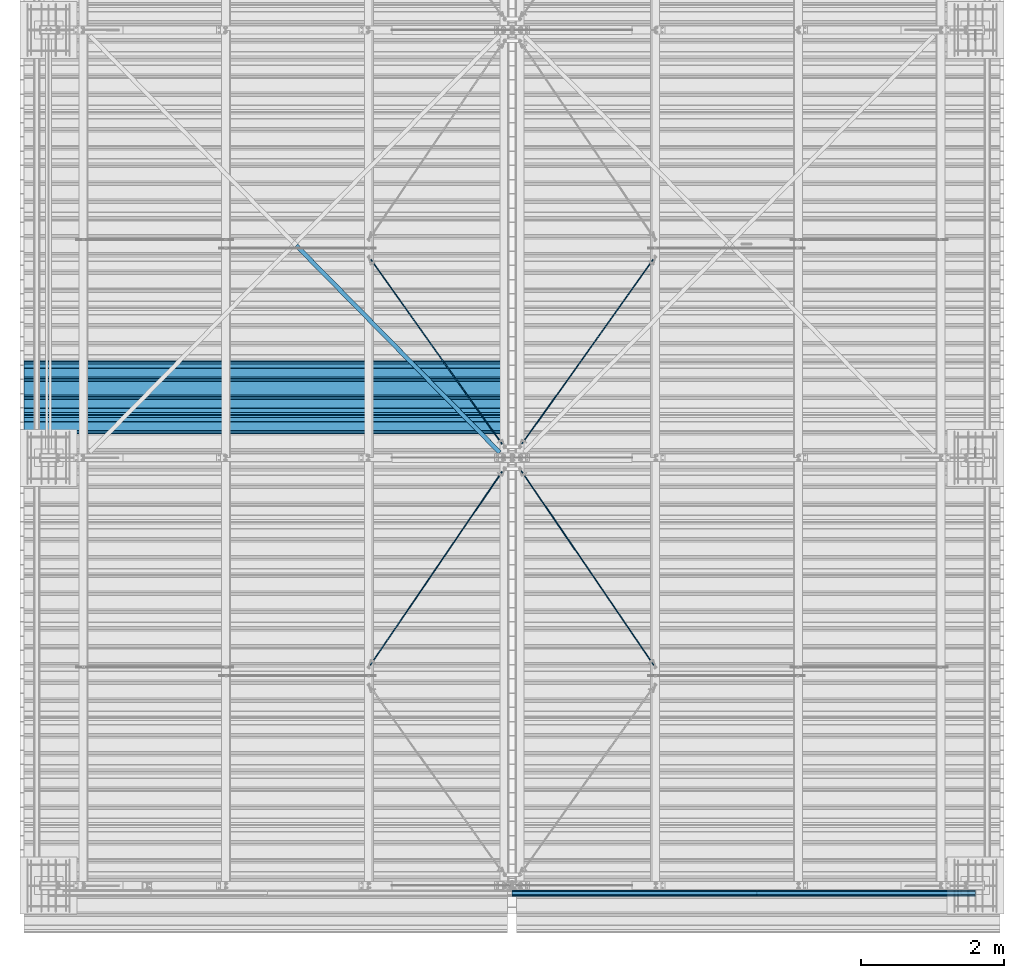
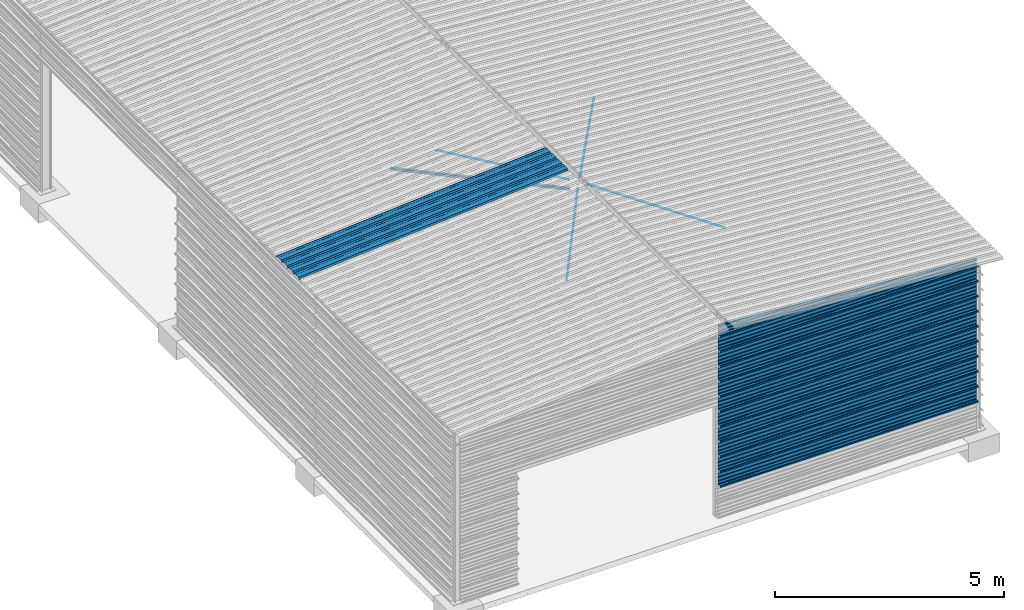
# One storey, part 7 of 70: 17 beams, 17 elements without a shape of their own.
"""IFC2X3 building model written with IfcOpenShell, lengths in millimetres."""

from ifc_helpers import new_model, si_unit, frame, origin_with_axes, origin_2d_with_axis, place, context, subcontext, project, spatial, polyline, circle, l_section, outline, extrude, clip, halfspace, material, type_object, element, aggregate, save


model = new_model("IFC2X3")

# Units and contexts
model_context = context("Model", 3, precision=1e-05, world=origin_with_axes())
body_context = subcontext(model_context, "Body", "Model", "MODEL_VIEW")
ifc_project = project(units=[si_unit("LENGTHUNIT", "METRE", prefix="MILLI"), si_unit("AREAUNIT", "SQUARE_METRE"), si_unit("VOLUMEUNIT", "CUBIC_METRE"), si_unit("MASSUNIT", "GRAM", prefix="KILO"), si_unit("TIMEUNIT", "SECOND"), si_unit("PLANEANGLEUNIT", "RADIAN"), si_unit("SOLIDANGLEUNIT", "STERADIAN"), si_unit("THERMODYNAMICTEMPERATUREUNIT", "DEGREE_CELSIUS"), si_unit("LUMINOUSINTENSITYUNIT", "LUMEN")], contexts=[model_context])

# Site, building, storey
site_placement = place(None, origin_with_axes())
site = spatial("IfcSite", under=ifc_project, at=site_placement, CompositionType="ELEMENT")
building_placement = place(site_placement, origin_with_axes())
building = spatial("IfcBuilding", under=site, at=building_placement, Name="Undefined", CompositionType="ELEMENT")
storey_placement = place(building_placement, origin_with_axes())
storey = spatial("IfcBuildingStorey", under=building, at=storey_placement, Name="Undefined", CompositionType="ELEMENT", Elevation=0.0)

# Assembly, beam
assembly_1_placement = place(storey_placement, origin_with_axes())
assembly_1 = element("IfcElementAssembly", 1, at=assembly_1_placement, inside=storey, Name="Steel Assembly", AssemblyPlace="NOTDEFINED", PredefinedType="RIGID_FRAME")
ifc_material = material(Name="STEEL/S235JR")
beam_type_1 = type_object("IfcBeamType", Name="4.40", PredefinedType="NOTDEFINED")
beam_1_placement = place(assembly_1_placement, frame((6436.39248868039, 6850.0, 5336.31760454388), z_axis=(0.0766964990376782, 0.0, -0.997054485489817), x_axis=(-0.997054485489818, 0.0, -0.0766964990376602)))
beam_1 = element("IfcBeam", 2, at=beam_1_placement, type_object=beam_type_1, material=ifc_material, ObjectType="4.40", context=body_context, shape_type="SweptSolid", body=[
    extrude(outline(polyline([(509.415161132813, 19.5000000011705), (490.584838867188, 19.5000000011705), (468.084838867188, -20.4999999988113), (406.585784912109, -20.4999999988113), (404.585784912109, -18.4999999988122), (345.414215087891, -18.4999999988122), (343.414215087891, -20.4999999988113), (281.915161132813, -20.4999999988113), (259.415161132813, 19.5000000011705), (240.584854125977, 19.5000000011705), (218.084854125977, -20.4999999988113), (156.585784912109, -20.4999999988113), (154.585784912109, -18.4999999988122), (95.4142150878906, -18.4999999988122), (93.4142150878906, -20.4999999988113), (31.9151515960693, -20.4999999988113), (9.41515254974365, 19.5000000011705), (-9.41515254974365, 19.5000000011705), (-31.9151515960693, -20.4999999988113), (-93.4142150878906, -20.4999999988113), (-95.4142150878906, -18.4999999988122), (-154.585784912109, -18.4999999988122), (-156.585784912109, -20.4999999988113), (-218.084854125977, -20.4999999988113), (-240.584854125977, 19.5000000011705), (-259.415161132813, 19.5000000011705), (-281.915161132813, -20.4999999988113), (-343.414215087891, -20.4999999988113), (-345.414215087891, -18.4999999988122), (-404.585784912109, -18.4999999988122), (-406.585784912109, -20.4999999988113), (-468.084838867188, -20.4999999988113), (-490.584838867188, 19.5000000011705), (-509.415161132813, 19.5000000011705), (-516.482360839844, 6.9361057293263), (-517.353942871094, 7.42636680720625), (-510.0, 20.5000000011705), (-490.0, 20.5000000011705), (-467.5, -19.4999999988122), (-407.0, -19.4999999988122), (-405.0, -17.4999999988131), (-345.0, -17.4999999988131), (-343.0, -19.4999999988122), (-282.5, -19.4999999988122), (-260.0, 20.5000000011705), (-240.0, 20.5000000011705), (-217.5, -19.4999999988122), (-157.0, -19.4999999988122), (-155.0, -17.4999999988131), (-95.0, -17.4999999988131), (-93.0, -19.4999999988122), (-32.5, -19.4999999988122), (-10.0, 20.5000000011705), (10.0, 20.5000000011705), (32.5, -19.4999999988122), (93.0, -19.4999999988122), (95.0, -17.4999999988131), (155.0, -17.4999999988131), (157.0, -19.4999999988122), (217.5, -19.4999999988122), (240.0, 20.5000000011705), (260.0, 20.5000000011705), (282.5, -19.4999999988122), (343.0, -19.4999999988122), (345.0, -17.4999999988131), (405.0, -17.4999999988131), (407.0, -19.4999999988122), (467.5, -19.4999999988122), (490.0, 20.5000000011705), (510.0, 20.5000000011705), (517.353942871094, 7.42636680720625), (516.482360839844, 6.9361057293263), (509.415161132813, 19.5000000011705)])), frame((6799.99999999733, 2.8421709430404e-14, 0.0), z_axis=(-1.0, 0.0, 0.0), x_axis=(0.0, -1.0, 0.0)), (0.0, 0.0, 1.0), 6800.0),
])
aggregate(assembly_1, [beam_1])

assembly_2_placement = place(storey_placement, origin_with_axes())
assembly_2 = element("IfcElementAssembly", 3, at=assembly_2_placement, inside=storey, Name="Steel Assembly", AssemblyPlace="NOTDEFINED", PredefinedType="RIGID_FRAME")
beam_type_2 = type_object("IfcBeamType", Name="400", PredefinedType="NOTDEFINED")
beam_2_placement = place(assembly_2_placement, frame((13000.0, -105.5, 5018.25), z_axis=(0.0, -1.0, 0.0), x_axis=(-1.0, 0.0, 0.0)))
beam_2 = element("IfcBeam", 4, at=beam_2_placement, type_object=beam_type_2, material=ifc_material, ObjectType="400", context=body_context, shape_type="Clipping", body=[
    clip(extrude(outline(polyline([(218.25, -24.994083404541), (214.25, -31.8999996185303), (214.25, -45.5), (199.75, -45.5), (194.25, -42.5), (188.75, -45.5), (124.25, -45.5), (114.25, -41.5), (104.25, -45.5), (24.25, -45.5), (14.25, -41.5), (4.25, -45.5), (-75.75, -45.5), (-85.75, -41.5), (-95.75, -45.5), (-160.25, -45.5), (-165.75, -42.5), (-171.25, -45.5), (-185.75, -45.5), (-185.75, -30.711540222168), (-181.75, -23.8111782073975), (-181.75, 23.311637878418), (-185.75, 30.2119998931885), (-185.75, 44.5), (-217.25, 44.5), (-217.25, 34.7999992370605), (-218.25, 34.7999992370605), (-218.25, 45.5), (-184.75, 45.5), (-184.75, 30.480884552002), (-180.75, 23.5805225372314), (-180.75, -24.0800628662109), (-184.75, -30.9804248809814), (-184.75, -44.5), (-171.504989624023, -44.5), (-165.75, -41.360912322998), (-159.995010375977, -44.5), (-95.9425811767578, -44.5), (-85.75, -40.422966003418), (-75.5574188232422, -44.5), (4.05741739273071, -44.5), (14.25, -40.422966003418), (24.4425830841064, -44.5), (104.057418823242, -44.5), (114.25, -40.422966003418), (124.442581176758, -44.5), (188.495010375977, -44.5), (194.25, -41.360912322998), (200.004989624023, -44.5), (213.25, -44.5), (213.25, -31.6313018798828), (217.25, -24.7253856658936), (217.25, 21.7253856658936), (213.25, 28.6313018798828), (213.25, 42.0), (187.25, 42.0), (187.25, 32.5499992370605), (186.25, 32.5499992370605), (186.25, 43.0), (214.25, 43.0), (214.25, 28.8999996185303), (218.25, 21.994083404541), (218.25, -24.994083404541)])), frame((6500.0, 0.0, 0.0), z_axis=(-1.0, 0.0, 0.0), x_axis=(0.0, -1.0, 0.0)), (0.0, 0.0, 1.0), 6500.0), halfspace(frame((0.0, 418.250001003011, -45.0), z_axis=(-0.0766964990376778, -0.997054485489817, 0.0), x_axis=(0.0, 0.0, 1.0)), False)),
])
aggregate(assembly_2, [beam_2])

assembly_3_placement = place(storey_placement, origin_with_axes())
assembly_3 = element("IfcElementAssembly", 5, at=assembly_3_placement, inside=storey, Name="Steel Assembly", AssemblyPlace="NOTDEFINED", PredefinedType="RIGID_FRAME")
beam_3_placement = place(assembly_3_placement, frame((13000.0, -105.5, 4618.25), z_axis=(0.0, -1.0, 0.0), x_axis=(-1.0, 0.0, 0.0)))
beam_3 = element("IfcBeam", 6, at=beam_3_placement, type_object=beam_type_2, material=ifc_material, ObjectType="400", context=body_context, shape_type="Clipping", body=[
    clip(extrude(outline(polyline([(218.25, -24.994083404541), (214.25, -31.8999996185303), (214.25, -45.5), (199.75, -45.5), (194.25, -42.5), (188.75, -45.5), (124.25, -45.5), (114.25, -41.5), (104.25, -45.5), (24.25, -45.5), (14.25, -41.5), (4.25, -45.5), (-75.75, -45.5), (-85.75, -41.5), (-95.75, -45.5), (-160.25, -45.5), (-165.75, -42.5), (-171.25, -45.5), (-185.75, -45.5), (-185.75, -30.711540222168), (-181.75, -23.8111782073975), (-181.75, 23.311637878418), (-185.75, 30.2119998931885), (-185.75, 44.5), (-217.25, 44.5), (-217.25, 34.7999992370605), (-218.25, 34.7999992370605), (-218.25, 45.5), (-184.75, 45.5), (-184.75, 30.480884552002), (-180.75, 23.5805225372314), (-180.75, -24.0800628662109), (-184.75, -30.9804248809814), (-184.75, -44.5), (-171.504989624023, -44.5), (-165.75, -41.360912322998), (-159.995010375977, -44.5), (-95.9425811767578, -44.5), (-85.75, -40.422966003418), (-75.5574188232422, -44.5), (4.05741739273071, -44.5), (14.25, -40.422966003418), (24.4425830841064, -44.5), (104.057418823242, -44.5), (114.25, -40.422966003418), (124.442581176758, -44.5), (188.495010375977, -44.5), (194.25, -41.360912322998), (200.004989624023, -44.5), (213.25, -44.5), (213.25, -31.6313018798828), (217.25, -24.7253856658936), (217.25, 21.7253856658936), (213.25, 28.6313018798828), (213.25, 42.0), (187.25, 42.0), (187.25, 32.5499992370605), (186.25, 32.5499992370605), (186.25, 43.0), (214.25, 43.0), (214.25, 28.8999996185303), (218.25, 21.994083404541), (218.25, -24.994083404541)])), frame((6500.0, 0.0, 0.0), z_axis=(-1.0, 0.0, 0.0), x_axis=(0.0, -1.0, 0.0)), (0.0, 0.0, 1.0), 6500.0), halfspace(frame((0.0, 18.2500010030071, -45.0), z_axis=(-0.0766964990376778, -0.997054485489817, 0.0), x_axis=(0.0, 0.0, 1.0)), False)),
])
aggregate(assembly_3, [beam_3])

assembly_4_placement = place(storey_placement, origin_with_axes())
assembly_4 = element("IfcElementAssembly", 7, at=assembly_4_placement, inside=storey, Name="Steel Assembly", AssemblyPlace="NOTDEFINED", PredefinedType="RIGID_FRAME")
beam_4_placement = place(assembly_4_placement, frame((13000.0, -105.5, 4218.25), z_axis=(0.0, -1.0, 0.0), x_axis=(-1.0, 0.0, 0.0)))
beam_4 = element("IfcBeam", 8, at=beam_4_placement, type_object=beam_type_2, material=ifc_material, ObjectType="400", context=body_context, shape_type="SweptSolid", body=[
    extrude(outline(polyline([(218.25, -24.994083404541), (214.25, -31.8999996185303), (214.25, -45.5), (199.75, -45.5), (194.25, -42.5), (188.75, -45.5), (124.25, -45.5), (114.25, -41.5), (104.25, -45.5), (24.25, -45.5), (14.25, -41.5), (4.25, -45.5), (-75.75, -45.5), (-85.75, -41.5), (-95.75, -45.5), (-160.25, -45.5), (-165.75, -42.5), (-171.25, -45.5), (-185.75, -45.5), (-185.75, -30.711540222168), (-181.75, -23.8111782073975), (-181.75, 23.311637878418), (-185.75, 30.2119998931885), (-185.75, 44.5), (-217.25, 44.5), (-217.25, 34.7999992370605), (-218.25, 34.7999992370605), (-218.25, 45.5), (-184.75, 45.5), (-184.75, 30.480884552002), (-180.75, 23.5805225372314), (-180.75, -24.0800628662109), (-184.75, -30.9804248809814), (-184.75, -44.5), (-171.504989624023, -44.5), (-165.75, -41.360912322998), (-159.995010375977, -44.5), (-95.9425811767578, -44.5), (-85.75, -40.422966003418), (-75.5574188232422, -44.5), (4.05741739273071, -44.5), (14.25, -40.422966003418), (24.4425830841064, -44.5), (104.057418823242, -44.5), (114.25, -40.422966003418), (124.442581176758, -44.5), (188.495010375977, -44.5), (194.25, -41.360912322998), (200.004989624023, -44.5), (213.25, -44.5), (213.25, -31.6313018798828), (217.25, -24.7253856658936), (217.25, 21.7253856658936), (213.25, 28.6313018798828), (213.25, 42.0), (187.25, 42.0), (187.25, 32.5499992370605), (186.25, 32.5499992370605), (186.25, 43.0), (214.25, 43.0), (214.25, 28.8999996185303), (218.25, 21.994083404541), (218.25, -24.994083404541)])), frame((6500.0, 0.0, 0.0), z_axis=(-1.0, 0.0, 0.0), x_axis=(0.0, -1.0, 0.0)), (0.0, 0.0, 1.0), 6500.0),
])
aggregate(assembly_4, [beam_4])

assembly_5_placement = place(storey_placement, origin_with_axes())
assembly_5 = element("IfcElementAssembly", 9, at=assembly_5_placement, inside=storey, Name="Steel Assembly", AssemblyPlace="NOTDEFINED", PredefinedType="RIGID_FRAME")
beam_5_placement = place(assembly_5_placement, frame((13000.0, -105.5, 3818.25), z_axis=(0.0, -1.0, 0.0), x_axis=(-1.0, 0.0, 0.0)))
beam_5 = element("IfcBeam", 10, at=beam_5_placement, type_object=beam_type_2, material=ifc_material, ObjectType="400", context=body_context, shape_type="SweptSolid", body=[
    extrude(outline(polyline([(218.25, -24.994083404541), (214.25, -31.8999996185303), (214.25, -45.5), (199.75, -45.5), (194.25, -42.5), (188.75, -45.5), (124.25, -45.5), (114.25, -41.5), (104.25, -45.5), (24.25, -45.5), (14.25, -41.5), (4.25, -45.5), (-75.75, -45.5), (-85.75, -41.5), (-95.75, -45.5), (-160.25, -45.5), (-165.75, -42.5), (-171.25, -45.5), (-185.75, -45.5), (-185.75, -30.711540222168), (-181.75, -23.8111782073975), (-181.75, 23.311637878418), (-185.75, 30.2119998931885), (-185.75, 44.5), (-217.25, 44.5), (-217.25, 34.7999992370605), (-218.25, 34.7999992370605), (-218.25, 45.5), (-184.75, 45.5), (-184.75, 30.480884552002), (-180.75, 23.5805225372314), (-180.75, -24.0800628662109), (-184.75, -30.9804248809814), (-184.75, -44.5), (-171.504989624023, -44.5), (-165.75, -41.360912322998), (-159.995010375977, -44.5), (-95.9425811767578, -44.5), (-85.75, -40.422966003418), (-75.5574188232422, -44.5), (4.05741739273071, -44.5), (14.25, -40.422966003418), (24.4425830841064, -44.5), (104.057418823242, -44.5), (114.25, -40.422966003418), (124.442581176758, -44.5), (188.495010375977, -44.5), (194.25, -41.360912322998), (200.004989624023, -44.5), (213.25, -44.5), (213.25, -31.6313018798828), (217.25, -24.7253856658936), (217.25, 21.7253856658936), (213.25, 28.6313018798828), (213.25, 42.0), (187.25, 42.0), (187.25, 32.5499992370605), (186.25, 32.5499992370605), (186.25, 43.0), (214.25, 43.0), (214.25, 28.8999996185303), (218.25, 21.994083404541), (218.25, -24.994083404541)])), frame((6500.0, 0.0, 0.0), z_axis=(-1.0, 0.0, 0.0), x_axis=(0.0, -1.0, 0.0)), (0.0, 0.0, 1.0), 6500.0),
])
aggregate(assembly_5, [beam_5])

assembly_6_placement = place(storey_placement, origin_with_axes())
assembly_6 = element("IfcElementAssembly", 11, at=assembly_6_placement, inside=storey, Name="Steel Assembly", AssemblyPlace="NOTDEFINED", PredefinedType="RIGID_FRAME")
beam_6_placement = place(assembly_6_placement, frame((13000.0, -105.5, 3418.25), z_axis=(0.0, -1.0, 0.0), x_axis=(-1.0, 0.0, 0.0)))
beam_6 = element("IfcBeam", 12, at=beam_6_placement, type_object=beam_type_2, material=ifc_material, ObjectType="400", context=body_context, shape_type="SweptSolid", body=[
    extrude(outline(polyline([(218.25, -24.994083404541), (214.25, -31.8999996185303), (214.25, -45.5), (199.75, -45.5), (194.25, -42.5), (188.75, -45.5), (124.25, -45.5), (114.25, -41.5), (104.25, -45.5), (24.25, -45.5), (14.25, -41.5), (4.25, -45.5), (-75.75, -45.5), (-85.75, -41.5), (-95.75, -45.5), (-160.25, -45.5), (-165.75, -42.5), (-171.25, -45.5), (-185.75, -45.5), (-185.75, -30.711540222168), (-181.75, -23.8111782073975), (-181.75, 23.311637878418), (-185.75, 30.2119998931885), (-185.75, 44.5), (-217.25, 44.5), (-217.25, 34.7999992370605), (-218.25, 34.7999992370605), (-218.25, 45.5), (-184.75, 45.5), (-184.75, 30.480884552002), (-180.75, 23.5805225372314), (-180.75, -24.0800628662109), (-184.75, -30.9804248809814), (-184.75, -44.5), (-171.504989624023, -44.5), (-165.75, -41.360912322998), (-159.995010375977, -44.5), (-95.9425811767578, -44.5), (-85.75, -40.422966003418), (-75.5574188232422, -44.5), (4.05741739273071, -44.5), (14.25, -40.422966003418), (24.4425830841064, -44.5), (104.057418823242, -44.5), (114.25, -40.422966003418), (124.442581176758, -44.5), (188.495010375977, -44.5), (194.25, -41.360912322998), (200.004989624023, -44.5), (213.25, -44.5), (213.25, -31.6313018798828), (217.25, -24.7253856658936), (217.25, 21.7253856658936), (213.25, 28.6313018798828), (213.25, 42.0), (187.25, 42.0), (187.25, 32.5499992370605), (186.25, 32.5499992370605), (186.25, 43.0), (214.25, 43.0), (214.25, 28.8999996185303), (218.25, 21.994083404541), (218.25, -24.994083404541)])), frame((6500.0, 0.0, 0.0), z_axis=(-1.0, 0.0, 0.0), x_axis=(0.0, -1.0, 0.0)), (0.0, 0.0, 1.0), 6500.0),
])
aggregate(assembly_6, [beam_6])

assembly_7_placement = place(storey_placement, origin_with_axes())
assembly_7 = element("IfcElementAssembly", 13, at=assembly_7_placement, inside=storey, Name="Steel Assembly", AssemblyPlace="NOTDEFINED", PredefinedType="RIGID_FRAME")
beam_7_placement = place(assembly_7_placement, frame((13000.0, -105.5, 3018.25), z_axis=(0.0, -1.0, 0.0), x_axis=(-1.0, 0.0, 0.0)))
beam_7 = element("IfcBeam", 14, at=beam_7_placement, type_object=beam_type_2, material=ifc_material, ObjectType="400", context=body_context, shape_type="SweptSolid", body=[
    extrude(outline(polyline([(218.25, -24.994083404541), (214.25, -31.8999996185303), (214.25, -45.5), (199.75, -45.5), (194.25, -42.5), (188.75, -45.5), (124.25, -45.5), (114.25, -41.5), (104.25, -45.5), (24.25, -45.5), (14.25, -41.5), (4.25, -45.5), (-75.75, -45.5), (-85.75, -41.5), (-95.75, -45.5), (-160.25, -45.5), (-165.75, -42.5), (-171.25, -45.5), (-185.75, -45.5), (-185.75, -30.711540222168), (-181.75, -23.8111782073975), (-181.75, 23.311637878418), (-185.75, 30.2119998931885), (-185.75, 44.5), (-217.25, 44.5), (-217.25, 34.7999992370605), (-218.25, 34.7999992370605), (-218.25, 45.5), (-184.75, 45.5), (-184.75, 30.480884552002), (-180.75, 23.5805225372314), (-180.75, -24.0800628662109), (-184.75, -30.9804248809814), (-184.75, -44.5), (-171.504989624023, -44.5), (-165.75, -41.360912322998), (-159.995010375977, -44.5), (-95.9425811767578, -44.5), (-85.75, -40.422966003418), (-75.5574188232422, -44.5), (4.05741739273071, -44.5), (14.25, -40.422966003418), (24.4425830841064, -44.5), (104.057418823242, -44.5), (114.25, -40.422966003418), (124.442581176758, -44.5), (188.495010375977, -44.5), (194.25, -41.360912322998), (200.004989624023, -44.5), (213.25, -44.5), (213.25, -31.6313018798828), (217.25, -24.7253856658936), (217.25, 21.7253856658936), (213.25, 28.6313018798828), (213.25, 42.0), (187.25, 42.0), (187.25, 32.5499992370605), (186.25, 32.5499992370605), (186.25, 43.0), (214.25, 43.0), (214.25, 28.8999996185303), (218.25, 21.994083404541), (218.25, -24.994083404541)])), frame((6500.0, 0.0, 0.0), z_axis=(-1.0, 0.0, 0.0), x_axis=(0.0, -1.0, 0.0)), (0.0, 0.0, 1.0), 6500.0),
])
aggregate(assembly_7, [beam_7])

assembly_8_placement = place(storey_placement, origin_with_axes())
assembly_8 = element("IfcElementAssembly", 15, at=assembly_8_placement, inside=storey, Name="Steel Assembly", AssemblyPlace="NOTDEFINED", PredefinedType="RIGID_FRAME")
beam_8_placement = place(assembly_8_placement, frame((13000.0, -105.5, 2618.25), z_axis=(0.0, -1.0, 0.0), x_axis=(-1.0, 0.0, 0.0)))
beam_8 = element("IfcBeam", 16, at=beam_8_placement, type_object=beam_type_2, material=ifc_material, ObjectType="400", context=body_context, shape_type="SweptSolid", body=[
    extrude(outline(polyline([(218.25, -24.994083404541), (214.25, -31.8999996185303), (214.25, -45.5), (199.75, -45.5), (194.25, -42.5), (188.75, -45.5), (124.25, -45.5), (114.25, -41.5), (104.25, -45.5), (24.25, -45.5), (14.25, -41.5), (4.25, -45.5), (-75.75, -45.5), (-85.75, -41.5), (-95.75, -45.5), (-160.25, -45.5), (-165.75, -42.5), (-171.25, -45.5), (-185.75, -45.5), (-185.75, -30.711540222168), (-181.75, -23.8111782073975), (-181.75, 23.311637878418), (-185.75, 30.2119998931885), (-185.75, 44.5), (-217.25, 44.5), (-217.25, 34.7999992370605), (-218.25, 34.7999992370605), (-218.25, 45.5), (-184.75, 45.5), (-184.75, 30.480884552002), (-180.75, 23.5805225372314), (-180.75, -24.0800628662109), (-184.75, -30.9804248809814), (-184.75, -44.5), (-171.504989624023, -44.5), (-165.75, -41.360912322998), (-159.995010375977, -44.5), (-95.9425811767578, -44.5), (-85.75, -40.422966003418), (-75.5574188232422, -44.5), (4.05741739273071, -44.5), (14.25, -40.422966003418), (24.4425830841064, -44.5), (104.057418823242, -44.5), (114.25, -40.422966003418), (124.442581176758, -44.5), (188.495010375977, -44.5), (194.25, -41.360912322998), (200.004989624023, -44.5), (213.25, -44.5), (213.25, -31.6313018798828), (217.25, -24.7253856658936), (217.25, 21.7253856658936), (213.25, 28.6313018798828), (213.25, 42.0), (187.25, 42.0), (187.25, 32.5499992370605), (186.25, 32.5499992370605), (186.25, 43.0), (214.25, 43.0), (214.25, 28.8999996185303), (218.25, 21.994083404541), (218.25, -24.994083404541)])), frame((6500.0, 0.0, 0.0), z_axis=(-1.0, 0.0, 0.0), x_axis=(0.0, -1.0, 0.0)), (0.0, 0.0, 1.0), 6500.0),
])
aggregate(assembly_8, [beam_8])

assembly_9_placement = place(storey_placement, origin_with_axes())
assembly_9 = element("IfcElementAssembly", 17, at=assembly_9_placement, inside=storey, Name="Steel Assembly", AssemblyPlace="NOTDEFINED", PredefinedType="RIGID_FRAME")
beam_9_placement = place(assembly_9_placement, frame((13000.0, -105.5, 2218.25), z_axis=(0.0, -1.0, 0.0), x_axis=(-1.0, 0.0, 0.0)))
beam_9 = element("IfcBeam", 18, at=beam_9_placement, type_object=beam_type_2, material=ifc_material, ObjectType="400", context=body_context, shape_type="SweptSolid", body=[
    extrude(outline(polyline([(218.25, -24.994083404541), (214.25, -31.8999996185303), (214.25, -45.5), (199.75, -45.5), (194.25, -42.5), (188.75, -45.5), (124.25, -45.5), (114.25, -41.5), (104.25, -45.5), (24.25, -45.5), (14.25, -41.5), (4.25, -45.5), (-75.75, -45.5), (-85.75, -41.5), (-95.75, -45.5), (-160.25, -45.5), (-165.75, -42.5), (-171.25, -45.5), (-185.75, -45.5), (-185.75, -30.711540222168), (-181.75, -23.8111782073975), (-181.75, 23.311637878418), (-185.75, 30.2119998931885), (-185.75, 44.5), (-217.25, 44.5), (-217.25, 34.7999992370605), (-218.25, 34.7999992370605), (-218.25, 45.5), (-184.75, 45.5), (-184.75, 30.480884552002), (-180.75, 23.5805225372314), (-180.75, -24.0800628662109), (-184.75, -30.9804248809814), (-184.75, -44.5), (-171.504989624023, -44.5), (-165.75, -41.360912322998), (-159.995010375977, -44.5), (-95.9425811767578, -44.5), (-85.75, -40.422966003418), (-75.5574188232422, -44.5), (4.05741739273071, -44.5), (14.25, -40.422966003418), (24.4425830841064, -44.5), (104.057418823242, -44.5), (114.25, -40.422966003418), (124.442581176758, -44.5), (188.495010375977, -44.5), (194.25, -41.360912322998), (200.004989624023, -44.5), (213.25, -44.5), (213.25, -31.6313018798828), (217.25, -24.7253856658936), (217.25, 21.7253856658936), (213.25, 28.6313018798828), (213.25, 42.0), (187.25, 42.0), (187.25, 32.5499992370605), (186.25, 32.5499992370605), (186.25, 43.0), (214.25, 43.0), (214.25, 28.8999996185303), (218.25, 21.994083404541), (218.25, -24.994083404541)])), frame((6500.0, 0.0, 0.0), z_axis=(-1.0, 0.0, 0.0), x_axis=(0.0, -1.0, 0.0)), (0.0, 0.0, 1.0), 6500.0),
])
aggregate(assembly_9, [beam_9])

assembly_10_placement = place(storey_placement, origin_with_axes())
assembly_10 = element("IfcElementAssembly", 19, at=assembly_10_placement, inside=storey, Name="Steel Assembly", AssemblyPlace="NOTDEFINED", PredefinedType="RIGID_FRAME")
beam_10_placement = place(assembly_10_placement, frame((13000.0, -105.5, 1818.25), z_axis=(0.0, -1.0, 0.0), x_axis=(-1.0, 0.0, 0.0)))
beam_10 = element("IfcBeam", 20, at=beam_10_placement, type_object=beam_type_2, material=ifc_material, ObjectType="400", context=body_context, shape_type="SweptSolid", body=[
    extrude(outline(polyline([(218.25, -24.994083404541), (214.25, -31.8999996185303), (214.25, -45.5), (199.75, -45.5), (194.25, -42.5), (188.75, -45.5), (124.25, -45.5), (114.25, -41.5), (104.25, -45.5), (24.25, -45.5), (14.25, -41.5), (4.25, -45.5), (-75.75, -45.5), (-85.75, -41.5), (-95.75, -45.5), (-160.25, -45.5), (-165.75, -42.5), (-171.25, -45.5), (-185.75, -45.5), (-185.75, -30.711540222168), (-181.75, -23.8111782073975), (-181.75, 23.311637878418), (-185.75, 30.2119998931885), (-185.75, 44.5), (-217.25, 44.5), (-217.25, 34.7999992370605), (-218.25, 34.7999992370605), (-218.25, 45.5), (-184.75, 45.5), (-184.75, 30.480884552002), (-180.75, 23.5805225372314), (-180.75, -24.0800628662109), (-184.75, -30.9804248809814), (-184.75, -44.5), (-171.504989624023, -44.5), (-165.75, -41.360912322998), (-159.995010375977, -44.5), (-95.9425811767578, -44.5), (-85.75, -40.422966003418), (-75.5574188232422, -44.5), (4.05741739273071, -44.5), (14.25, -40.422966003418), (24.4425830841064, -44.5), (104.057418823242, -44.5), (114.25, -40.422966003418), (124.442581176758, -44.5), (188.495010375977, -44.5), (194.25, -41.360912322998), (200.004989624023, -44.5), (213.25, -44.5), (213.25, -31.6313018798828), (217.25, -24.7253856658936), (217.25, 21.7253856658936), (213.25, 28.6313018798828), (213.25, 42.0), (187.25, 42.0), (187.25, 32.5499992370605), (186.25, 32.5499992370605), (186.25, 43.0), (214.25, 43.0), (214.25, 28.8999996185303), (218.25, 21.994083404541), (218.25, -24.994083404541)])), frame((6500.0, 0.0, 0.0), z_axis=(-1.0, 0.0, 0.0), x_axis=(0.0, -1.0, 0.0)), (0.0, 0.0, 1.0), 6500.0),
])
aggregate(assembly_10, [beam_10])

assembly_11_placement = place(storey_placement, origin_with_axes())
assembly_11 = element("IfcElementAssembly", 21, at=assembly_11_placement, inside=storey, Name="Steel Assembly", AssemblyPlace="NOTDEFINED", PredefinedType="RIGID_FRAME")
beam_11_placement = place(assembly_11_placement, frame((13000.0, -105.5, 1418.25), z_axis=(0.0, -1.0, 0.0), x_axis=(-1.0, 0.0, 0.0)))
beam_11 = element("IfcBeam", 22, at=beam_11_placement, type_object=beam_type_2, material=ifc_material, ObjectType="400", context=body_context, shape_type="SweptSolid", body=[
    extrude(outline(polyline([(218.25, -24.994083404541), (214.25, -31.8999996185303), (214.25, -45.5), (199.75, -45.5), (194.25, -42.5), (188.75, -45.5), (124.25, -45.5), (114.25, -41.5), (104.25, -45.5), (24.25, -45.5), (14.25, -41.5), (4.25, -45.5), (-75.75, -45.5), (-85.75, -41.5), (-95.75, -45.5), (-160.25, -45.5), (-165.75, -42.5), (-171.25, -45.5), (-185.75, -45.5), (-185.75, -30.711540222168), (-181.75, -23.8111782073975), (-181.75, 23.311637878418), (-185.75, 30.2119998931885), (-185.75, 44.5), (-217.25, 44.5), (-217.25, 34.7999992370605), (-218.25, 34.7999992370605), (-218.25, 45.5), (-184.75, 45.5), (-184.75, 30.480884552002), (-180.75, 23.5805225372314), (-180.75, -24.0800628662109), (-184.75, -30.9804248809814), (-184.75, -44.5), (-171.504989624023, -44.5), (-165.75, -41.360912322998), (-159.995010375977, -44.5), (-95.9425811767578, -44.5), (-85.75, -40.422966003418), (-75.5574188232422, -44.5), (4.05741739273071, -44.5), (14.25, -40.422966003418), (24.4425830841064, -44.5), (104.057418823242, -44.5), (114.25, -40.422966003418), (124.442581176758, -44.5), (188.495010375977, -44.5), (194.25, -41.360912322998), (200.004989624023, -44.5), (213.25, -44.5), (213.25, -31.6313018798828), (217.25, -24.7253856658936), (217.25, 21.7253856658936), (213.25, 28.6313018798828), (213.25, 42.0), (187.25, 42.0), (187.25, 32.5499992370605), (186.25, 32.5499992370605), (186.25, 43.0), (214.25, 43.0), (214.25, 28.8999996185303), (218.25, 21.994083404541), (218.25, -24.994083404541)])), frame((6500.0, 0.0, 0.0), z_axis=(-1.0, 0.0, 0.0), x_axis=(0.0, -1.0, 0.0)), (0.0, 0.0, 1.0), 6500.0),
])
aggregate(assembly_11, [beam_11])

assembly_12_placement = place(storey_placement, origin_with_axes())
assembly_12 = element("IfcElementAssembly", 23, at=assembly_12_placement, inside=storey, Name="Steel Assembly", AssemblyPlace="NOTDEFINED", PredefinedType="RIGID_FRAME")
beam_12_placement = place(assembly_12_placement, frame((13000.0, -105.5, 1018.25), z_axis=(0.0, -1.0, 0.0), x_axis=(-1.0, 0.0, 0.0)))
beam_12 = element("IfcBeam", 24, at=beam_12_placement, type_object=beam_type_2, material=ifc_material, ObjectType="400", context=body_context, shape_type="SweptSolid", body=[
    extrude(outline(polyline([(218.25, -24.994083404541), (214.25, -31.8999996185303), (214.25, -45.5), (199.75, -45.5), (194.25, -42.5), (188.75, -45.5), (124.25, -45.5), (114.25, -41.5), (104.25, -45.5), (24.25, -45.5), (14.25, -41.5), (4.25, -45.5), (-75.75, -45.5), (-85.75, -41.5), (-95.75, -45.5), (-160.25, -45.5), (-165.75, -42.5), (-171.25, -45.5), (-185.75, -45.5), (-185.75, -30.711540222168), (-181.75, -23.8111782073975), (-181.75, 23.311637878418), (-185.75, 30.2119998931885), (-185.75, 44.5), (-217.25, 44.5), (-217.25, 34.7999992370605), (-218.25, 34.7999992370605), (-218.25, 45.5), (-184.75, 45.5), (-184.75, 30.480884552002), (-180.75, 23.5805225372314), (-180.75, -24.0800628662109), (-184.75, -30.9804248809814), (-184.75, -44.5), (-171.504989624023, -44.5), (-165.75, -41.360912322998), (-159.995010375977, -44.5), (-95.9425811767578, -44.5), (-85.75, -40.422966003418), (-75.5574188232422, -44.5), (4.05741739273071, -44.5), (14.25, -40.422966003418), (24.4425830841064, -44.5), (104.057418823242, -44.5), (114.25, -40.422966003418), (124.442581176758, -44.5), (188.495010375977, -44.5), (194.25, -41.360912322998), (200.004989624023, -44.5), (213.25, -44.5), (213.25, -31.6313018798828), (217.25, -24.7253856658936), (217.25, 21.7253856658936), (213.25, 28.6313018798828), (213.25, 42.0), (187.25, 42.0), (187.25, 32.5499992370605), (186.25, 32.5499992370605), (186.25, 43.0), (214.25, 43.0), (214.25, 28.8999996185303), (218.25, 21.994083404541), (218.25, -24.994083404541)])), frame((6500.0, 0.0, 0.0), z_axis=(-1.0, 0.0, 0.0), x_axis=(0.0, -1.0, 0.0)), (0.0, 0.0, 1.0), 6500.0),
])
aggregate(assembly_12, [beam_12])

assembly_13_placement = place(storey_placement, origin_with_axes())
assembly_13 = element("IfcElementAssembly", 25, at=assembly_13_placement, inside=storey, Name="Steel Assembly", AssemblyPlace="NOTDEFINED", PredefinedType="RIGID_FRAME")
beam_type_3 = type_object("IfcBeamType", Name="D14", PredefinedType="NOTDEFINED")
beam_13_placement = place(assembly_13_placement, frame((6358.2984486833, 6196.74598965784, 5199.42484494783), z_axis=(0.0766964990376782, 0.0, -0.997054485489817), x_axis=(-0.57921819911489, 0.813953996161451, -0.0445552460088377)))
beam_13 = element("IfcBeam", 26, at=beam_13_placement, type_object=beam_type_3, material=ifc_material, Name="THREAD60MM", ObjectType="D14", context=body_context, shape_type="SweptSolid", body=[
    extrude(circle(Radius=7.0, at=origin_2d_with_axis()), frame((3171.4817490804, -6.87705480470219e-15, 2.2006575375047e-14), z_axis=(-1.0, 0.0, 0.0), x_axis=(0.0, -1.0, 0.0)), (0.0, 0.0, 1.0), 3171.48),
])
aggregate(assembly_13, [beam_13])

assembly_14_placement = place(storey_placement, origin_with_axes())
assembly_14 = element("IfcElementAssembly", 27, at=assembly_14_placement, inside=storey, Name="Steel Assembly", AssemblyPlace="NOTDEFINED", PredefinedType="RIGID_FRAME")
beam_14_placement = place(assembly_14_placement, frame((6360.24089837314, 5804.00540100532, 5199.57426415064), z_axis=(0.0766964990376782, 0.0, -0.997054485489817), x_axis=(-0.5623502269338, -0.825766911902807, -0.0432577099949295)))
beam_14 = element("IfcBeam", 28, at=beam_14_placement, type_object=beam_type_3, material=ifc_material, Name="THREAD60MM", ObjectType="D14", context=body_context, shape_type="SweptSolid", body=[
    extrude(circle(Radius=7.0, at=origin_2d_with_axis()), frame((3282.74775890457, 6.38998370626533e-13, 0.0), z_axis=(-1.0, 0.0, 0.0), x_axis=(0.0, -1.0, 0.0)), (0.0, 0.0, 1.0), 3282.75),
])
aggregate(assembly_14, [beam_14])

assembly_15_placement = place(storey_placement, origin_with_axes())
assembly_15 = element("IfcElementAssembly", 29, at=assembly_15_placement, inside=storey, Name="Steel Assembly", AssemblyPlace="NOTDEFINED", PredefinedType="RIGID_FRAME")
beam_15_placement = place(assembly_15_placement, frame((6642.75817654875, 6198.23082616812, 5199.34356608337), z_axis=(-0.0766964990376782, 0.0, -0.997054485489817), x_axis=(0.57921819911489, 0.813953996161451, -0.0445552460088378)))
beam_15 = element("IfcBeam", 30, at=beam_15_placement, type_object=beam_type_3, material=ifc_material, Name="THREAD60MM", ObjectType="D14", context=body_context, shape_type="SweptSolid", body=[
    extrude(circle(Radius=7.0, at=origin_2d_with_axis()), frame((3169.65752250536, -1.48189795423847e-12, 8.87500784512542e-13), z_axis=(-1.0, 0.0, 0.0), x_axis=(0.0, -1.0, 0.0)), (0.0, 0.0, 1.0), 3169.66),
])
aggregate(assembly_15, [beam_15])

assembly_16_placement = place(storey_placement, origin_with_axes())
assembly_16 = element("IfcElementAssembly", 31, at=assembly_16_placement, inside=storey, Name="Steel Assembly", AssemblyPlace="NOTDEFINED", PredefinedType="RIGID_FRAME")
beam_16_placement = place(assembly_16_placement, frame((6630.90527163433, 5817.00655136214, 5200.25532799996), z_axis=(-0.0766964990376782, 0.0, -0.997054485489817), x_axis=(0.562350226933823, -0.825766911902794, -0.0432577099948882)))
beam_16 = element("IfcBeam", 32, at=beam_16_placement, type_object=beam_type_3, material=ifc_material, Name="THREAD60MM", ObjectType="D14", context=body_context, shape_type="SweptSolid", body=[
    extrude(circle(Radius=7.0, at=origin_2d_with_axis()), frame((3298.49209325387, -1.92913735818357e-12, -2.28878866779655e-14), z_axis=(-1.0, 0.0, 0.0), x_axis=(0.0, -1.0, 0.0)), (0.0, 0.0, 1.0), 3298.49),
])
aggregate(assembly_16, [beam_16])

assembly_17_placement = place(storey_placement, origin_with_axes())
assembly_17 = element("IfcElementAssembly", 33, at=assembly_17_placement, inside=storey, Name="Steel Assembly", AssemblyPlace="NOTDEFINED", PredefinedType="RIGID_FRAME")
beam_type_4 = type_object("IfcBeamType", PredefinedType="NOTDEFINED")
beam_17_placement = place(assembly_17_placement, frame((3475.43110670883, 8978.24877391184, 4820.0014161823), z_axis=(0.0766964990376782, 0.0, -0.997054485489817), x_axis=(0.700122412215615, -0.711988894219269, 0.0538555700165856)))
beam_17 = element("IfcBeam", 34, at=beam_17_placement, type_object=beam_type_4, material=ifc_material, Name="POUTRE", context=body_context, shape_type="Clipping", body=[
    clip(extrude(l_section(Depth=60.0, Width=60.0, Thickness=6.0, FilletRadius=8.0, EdgeRadius=4.0, at=origin_2d_with_axis()), frame((4076.16336990518, 7.95489332590265e-14, -2.8284065158765e-14), z_axis=(-1.0, 0.0, 0.0), x_axis=(0.0, -1.0, 0.0)), (0.0, 0.0, 1.0), 4136.91), halfspace(frame((3.4289438453734, -29.9999999942156, 1.07770301838173e-06), z_axis=(1.0, 0.0, 0.0), x_axis=(0.0, 0.0, 1.0)), True)),
])
aggregate(assembly_17, [beam_17])

save(model, "model.ifc")
